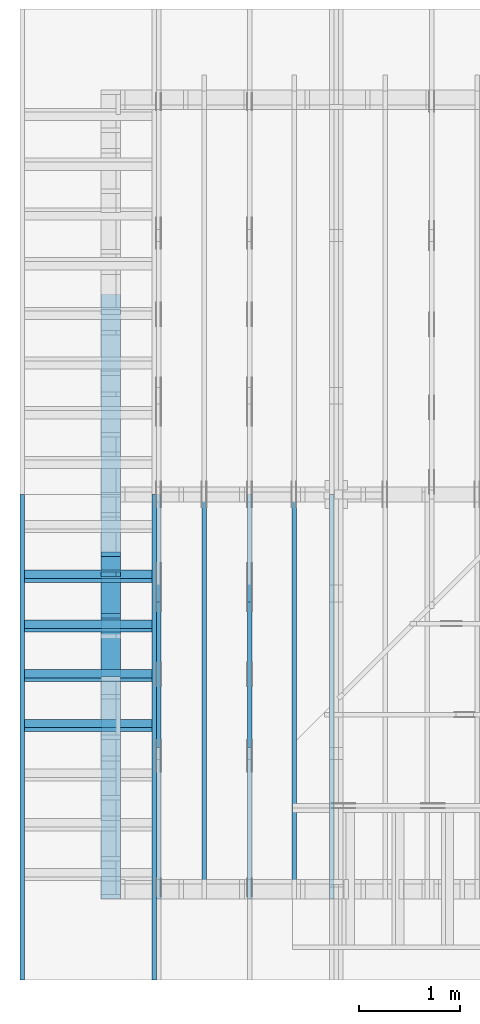
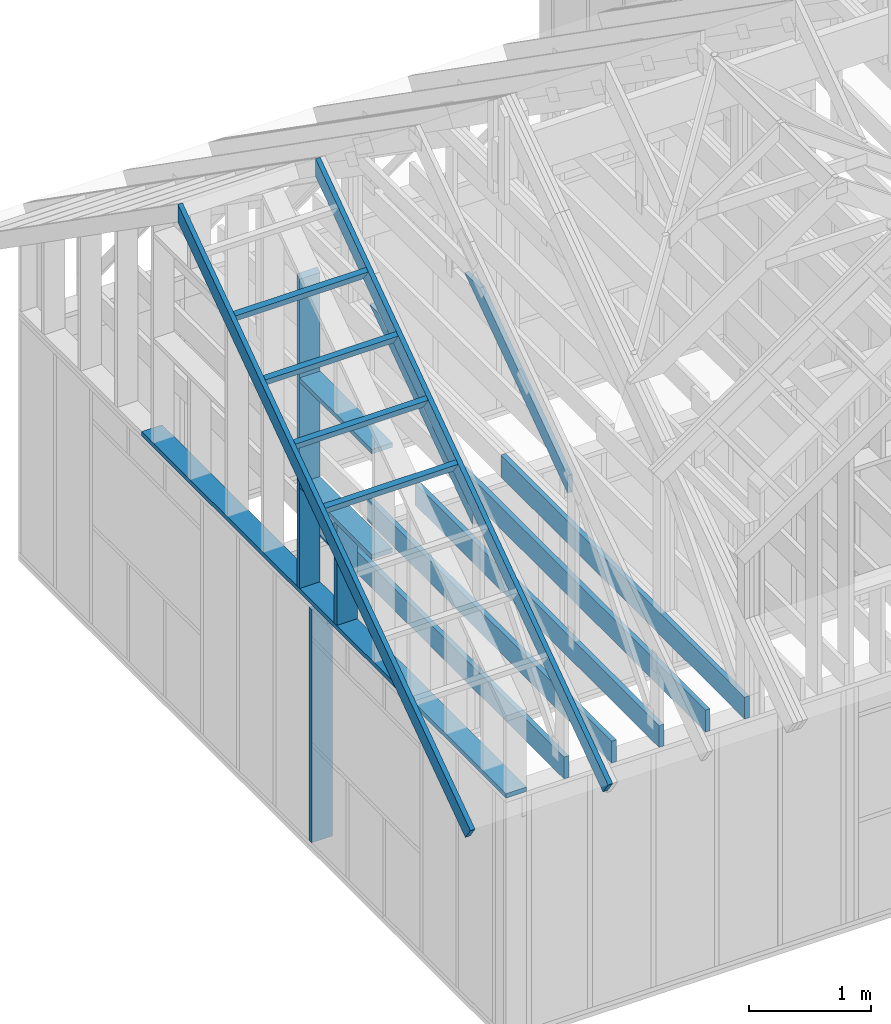
# One storey, part 5 of 70: 19 members, 8 elements without a shape of their own.
"""IFC2X3 building model written with IfcOpenShell, lengths in millimetres."""

from ifc_helpers import new_model, si_unit, frame, origin, origin_with_axes, origin_2d, place, context, project, spatial, faceted_brep, element, aggregate, save


model = new_model("IFC2X3")

# Units and contexts
model_context = context("Model", 3, precision=1e-05, world=origin())
plan_context = context("Plan", 2, precision=1e-05, world=origin_2d())
ifc_project = project(units=[si_unit("LENGTHUNIT", "METRE", prefix="MILLI"), si_unit("AREAUNIT", "SQUARE_METRE"), si_unit("VOLUMEUNIT", "CUBIC_METRE"), si_unit("SOLIDANGLEUNIT", "STERADIAN"), si_unit("PLANEANGLEUNIT", "RADIAN"), si_unit("MASSUNIT", "GRAM"), si_unit("TIMEUNIT", "SECOND"), si_unit("THERMODYNAMICTEMPERATUREUNIT", "DEGREE_CELSIUS"), si_unit("LUMINOUSINTENSITYUNIT", "LUMEN")], contexts=[model_context, plan_context])

# Site, building, storey
site_placement = place(None, origin_with_axes())
site = spatial("IfcSite", under=ifc_project, at=site_placement, CompositionType="ELEMENT")
building_placement = place(site_placement, origin_with_axes())
building = spatial("IfcBuilding", under=site, at=building_placement, Name="Layout 1", CompositionType="ELEMENT")
storey_placement = place(building_placement, origin_with_axes())
storey = spatial("IfcBuildingStorey", under=building, at=storey_placement, Name="Storey 1", CompositionType="ELEMENT", Elevation=0.0)

# Assembly, member
assembly_1_placement = place(storey_placement, frame((1969.9999999999982, 8000.000000000001, 1.1021457184401395e-14), z_axis=(-1.0, 1.836909530733566e-16, 6.123031769111886e-17), x_axis=(-1.836909530733566e-16, -1.0, 0.0)))
assembly_1 = element("IfcElementAssembly", 1, at=assembly_1_placement, inside=storey, Name="T11", AssemblyPlace="FACTORY", PredefinedType="TRUSS")
member_1_placement = place(assembly_1_placement, frame((7999.999999999999, 220.0, -90.0), z_axis=(0.0, 0.0, 1.0), x_axis=(-1.0, 1.2246063538223773e-16, 0.0)))
member_1 = element("IfcMember", 2, at=member_1_placement, Name="B3", context=model_context, shape_type="Brep", body=[
    faceted_brep([(3999.9999999999995, 220.00000000000054, 45.0), (0.0, 220.00000000000054, 45.0), (0.0, 0.0, 45.0), (3999.9999999999995, 0.0, 45.0), (0.0, 220.00000000000054, 0.0), (3999.9999999999995, 220.00000000000054, 4.898425415289508e-13), (3999.9999999999995, 0.0, 4.898425415289508e-13), (0.0, 0.0, 0.0), (0.0, 0.0, 0.0), (2.755364296100349e-15, -3.3742366240998092e-31, 45.0), (2.969670408019265e-14, 220.0, 45.0), (2.69413397840923e-14, 220.0, -1.6496267940043512e-30), (3999.9999999999995, -7.347638122934263e-13, 7.805495731188194e-29), (3999.9999999999995, -7.320084479973259e-13, 45.0), (5.061354936149714e-31, 2.755364296100349e-15, 45.0), (0.0, 0.0, 0.0), (3999.9999999999995, 220.00000000000054, 0.0), (3999.9999999999995, 220.00000000000054, 45.0), (3999.9999999999995, 5.400124791776761e-13, 45.0), (3999.9999999999995, 5.400124791776761e-13, 0.0), (0.0, 220.0, 0.0), (0.0, 220.0, 45.0), (3999.9999999999995, 220.00000000000065, 45.0), (3999.9999999999995, 220.00000000000065, 6.310887241768095e-30)], [[[0, 1, 2, 3]], [[4, 5, 6, 7]], [[8, 9, 10, 11]], [[12, 13, 14, 15]], [[16, 17, 18, 19]], [[20, 21, 22, 23]]]),
])
aggregate(assembly_1, [member_1])

# Assembly, members
assembly_2_placement = place(storey_placement, frame((304.9999999999989, 8000.000000000001, 1.3776821480501744e-15), z_axis=(-1.0, 1.836909530733566e-16, 6.123031769111886e-17), x_axis=(-1.836909530733566e-16, -1.0, 0.0)))
assembly_2 = element("IfcElementAssembly", 3, at=assembly_2_placement, inside=storey, Name="T2", AssemblyPlace="FACTORY", PredefinedType="TRUSS")
member_2_placement = place(assembly_2_placement, frame((7999.999999999999, 220.0, -45.0), z_axis=(0.0, 0.0, 1.0), x_axis=(-1.0, 1.2246063538223773e-16, 0.0)))
member_2 = element("IfcMember", 4, at=member_2_placement, Name="B3", context=model_context, shape_type="Brep", body=[
    faceted_brep([(3999.9999999999995, 220.00000000000048, 45.0), (0.0, 220.00000000000048, 45.0), (0.0, 0.0, 45.0), (3999.9999999999995, 0.0, 45.0), (0.0, 220.00000000000048, 0.0), (3999.9999999999995, 220.00000000000048, 4.898425415289508e-13), (3999.9999999999995, 0.0, 4.898425415289508e-13), (0.0, 0.0, 0.0), (0.0, 0.0, 0.0), (2.755364296100349e-15, -3.3742366240998092e-31, 45.0), (2.969670408019265e-14, 220.0, 45.0), (2.69413397840923e-14, 220.0, -1.6496267940043512e-30), (3999.9999999999995, -7.347638122934263e-13, 7.457441671638533e-29), (3999.9999999999995, -7.320084479973259e-13, 45.0), (5.061354936149714e-31, 2.755364296100349e-15, 45.0), (0.0, 0.0, 0.0), (3999.9999999999995, 220.00000000000048, 0.0), (3999.9999999999995, 220.00000000000048, 45.0), (3999.9999999999995, 4.831690603168681e-13, 45.0), (3999.9999999999995, 4.831690603168681e-13, 0.0), (0.0, 220.0, 0.0), (0.0, 220.0, 45.0), (3999.9999999999995, 220.00000000000065, 45.0), (3999.9999999999995, 220.00000000000065, 9.466330862652142e-30)], [[[0, 1, 2, 3]], [[4, 5, 6, 7]], [[8, 9, 10, 11]], [[12, 13, 14, 15]], [[16, 17, 18, 19]], [[20, 21, 22, 23]]]),
])
member_3_placement = place(assembly_2_placement, frame((6583.168583270555, 1754.024964553922, -45.0), z_axis=(0.0, 0.0, 1.0), x_axis=(-0.8191520442887741, 0.573576436351357, 0.0)))
member_3 = element("IfcMember", 5, at=member_3_placement, Name="SC5", context=model_context, shape_type="Brep", body=[
    faceted_brep([(2065.5522207412555, 145.00000000430646, 45.0), (0.0, 145.00000000430646, 45.0), (101.53009304075658, 0.0, 45.0), (1858.470759763978, 0.0, 45.0), (0.0, 145.00000000430646, 0.0), (2065.5522207412555, 145.00000000430646, 2.529488373671663e-13), (1858.470759763978, 0.0, 2.2758951008000685e-13), (101.53009304075658, 0.0, 1.2433439704188764e-14), (101.53009304075658, 7.105427357601002e-15, 0.0), (101.53009304075658, 7.105427357601002e-15, 45.0), (2.842170943040401e-14, 145.00000000026287, 45.0), (2.842170943040401e-14, 145.00000000026287, -1.5777218104420236e-30), (1858.470759763978, 4.5968566477253265e-09, -1.6558206515312064e-29), (1858.470759763978, 4.5968594030896226e-09, 45.0), (101.53009304075658, 1.7528947204142885e-14, 45.0), (101.53009304075658, 1.4773582908042536e-14, -9.04591174894424e-31), (2065.552220741256, 145.00000000430566, 5.048709793414476e-29), (2065.552220741256, 145.00000000430566, 45.0), (1858.4707597639788, 4.59590410173405e-09, 45.0), (1858.4707597639788, 4.59590410173405e-09, 5.048709793414476e-29), (0.0, 145.00000000026284, 0.0), (0.0, 145.00000000026284, 45.0), (2065.5522207412555, 145.00000000430657, 45.0), (2065.5522207412555, 145.0000000043066, 7.888609052210118e-30)], [[[0, 1, 2, 3]], [[4, 5, 6, 7]], [[8, 9, 10, 11]], [[12, 13, 14, 15]], [[16, 17, 18, 19]], [[20, 21, 22, 23]]]),
])
aggregate(assembly_2, [member_2, member_3])

assembly_3_placement = place(storey_placement, frame((1204.9999999999989, 8000.000000000001, 1.3776821480501744e-15), z_axis=(-1.0, 1.836909530733566e-16, 6.123031769111886e-17), x_axis=(-1.836909530733566e-16, -1.0, 0.0)))
assembly_3 = element("IfcElementAssembly", 6, at=assembly_3_placement, inside=storey, Name="T2", AssemblyPlace="FACTORY", PredefinedType="TRUSS")
member_4_placement = place(assembly_3_placement, frame((7999.999999999999, 220.0, -45.0), z_axis=(0.0, 0.0, 1.0), x_axis=(-1.0, 1.2246063538223773e-16, 0.0)))
member_4 = element("IfcMember", 7, at=member_4_placement, Name="B3", context=model_context, shape_type="Brep", body=[
    faceted_brep([(3999.9999999999995, 220.00000000000048, 45.0), (0.0, 220.00000000000048, 45.0), (0.0, 0.0, 45.0), (3999.9999999999995, 0.0, 45.0), (0.0, 220.00000000000048, 0.0), (3999.9999999999995, 220.00000000000048, 4.898425415289508e-13), (3999.9999999999995, 0.0, 4.898425415289508e-13), (0.0, 0.0, 0.0), (0.0, 0.0, 0.0), (2.755364296100349e-15, -3.3742366240998092e-31, 45.0), (2.969670408019265e-14, 220.0, 45.0), (2.69413397840923e-14, 220.0, -1.6496267940043512e-30), (3999.9999999999995, -7.347638122934263e-13, 7.457441671638533e-29), (3999.9999999999995, -7.320084479973259e-13, 45.0), (5.061354936149714e-31, 2.755364296100349e-15, 45.0), (0.0, 0.0, 0.0), (3999.9999999999995, 220.00000000000048, 0.0), (3999.9999999999995, 220.00000000000048, 45.0), (3999.9999999999995, 4.831690603168681e-13, 45.0), (3999.9999999999995, 4.831690603168681e-13, 0.0), (0.0, 220.0, 0.0), (0.0, 220.0, 45.0), (3999.9999999999995, 220.00000000000065, 45.0), (3999.9999999999995, 220.00000000000065, 9.466330862652142e-30)], [[[0, 1, 2, 3]], [[4, 5, 6, 7]], [[8, 9, 10, 11]], [[12, 13, 14, 15]], [[16, 17, 18, 19]], [[20, 21, 22, 23]]]),
])
member_5_placement = place(assembly_3_placement, frame((6583.168583270555, 1754.024964553922, -45.0), z_axis=(0.0, 0.0, 1.0), x_axis=(-0.8191520442887741, 0.573576436351357, 0.0)))
member_5 = element("IfcMember", 8, at=member_5_placement, Name="SC5", context=model_context, shape_type="Brep", body=[
    faceted_brep([(2065.5522207412555, 145.00000000430646, 45.0), (0.0, 145.00000000430646, 45.0), (101.53009304075658, 0.0, 45.0), (1858.470759763978, 0.0, 45.0), (0.0, 145.00000000430646, 0.0), (2065.5522207412555, 145.00000000430646, 2.529488373671663e-13), (1858.470759763978, 0.0, 2.2758951008000685e-13), (101.53009304075658, 0.0, 1.2433439704188764e-14), (101.53009304075658, 7.105427357601002e-15, 0.0), (101.53009304075658, 7.105427357601002e-15, 45.0), (2.842170943040401e-14, 145.00000000026287, 45.0), (2.842170943040401e-14, 145.00000000026287, -1.5777218104420236e-30), (1858.470759763978, 4.5968566477253265e-09, -1.6558206515312064e-29), (1858.470759763978, 4.5968594030896226e-09, 45.0), (101.53009304075658, 1.7528947204142885e-14, 45.0), (101.53009304075658, 1.4773582908042536e-14, -9.04591174894424e-31), (2065.552220741256, 145.00000000430566, 5.048709793414476e-29), (2065.552220741256, 145.00000000430566, 45.0), (1858.4707597639788, 4.59590410173405e-09, 45.0), (1858.4707597639788, 4.59590410173405e-09, 5.048709793414476e-29), (0.0, 145.00000000026284, 0.0), (0.0, 145.00000000026284, 45.0), (2065.5522207412555, 145.00000000430657, 45.0), (2065.5522207412555, 145.0000000043066, 7.888609052210118e-30)], [[[0, 1, 2, 3]], [[4, 5, 6, 7]], [[8, 9, 10, 11]], [[12, 13, 14, 15]], [[16, 17, 18, 19]], [[20, 21, 22, 23]]]),
])
aggregate(assembly_3, [member_4, member_5])

# Assembly, member
assembly_4_placement = place(storey_placement, frame((754.9999999999991, 8000.000000000001, 1.3776821480501744e-15), z_axis=(-1.0, 1.836909530733566e-16, 6.123031769111886e-17), x_axis=(-1.836909530733566e-16, -1.0, 0.0)))
assembly_4 = element("IfcElementAssembly", 9, at=assembly_4_placement, inside=storey, Name="MB1", AssemblyPlace="FACTORY", PredefinedType="TRUSS")
member_6_placement = place(assembly_4_placement, frame((8000.000000000001, 220.0, -45.0), z_axis=(0.0, 0.0, 1.0), x_axis=(-1.0, 1.2246063538223773e-16, 0.0)))
member_6 = element("IfcMember", 10, at=member_6_placement, Name="B3", context=model_context, shape_type="Brep", body=[
    faceted_brep([(4000.0000000000005, 220.0000000000005, 45.0), (0.0, 220.0000000000005, 45.0), (0.0, 0.0, 45.0), (4000.0000000000005, 0.0, 45.0), (0.0, 220.0000000000005, 0.0), (4000.0000000000005, 220.0000000000005, 4.89842541528951e-13), (4000.0000000000005, 0.0, 4.89842541528951e-13), (0.0, 0.0, 0.0), (0.0, 0.0, 0.0), (2.755364296100349e-15, -3.3742366240998092e-31, 45.0), (2.969670408019265e-14, 220.0, 45.0), (2.69413397840923e-14, 220.0, -1.6496267940043512e-30), (4000.0000000000005, -7.347638122934265e-13, 7.631468701413364e-29), (4000.0000000000005, -7.320084479973261e-13, 45.0), (5.061354936149714e-31, 2.755364296100349e-15, 45.0), (0.0, 0.0, 0.0), (4000.0000000000005, 220.0000000000005, 0.0), (4000.0000000000005, 220.0000000000005, 45.0), (4000.0000000000005, 5.115907697472721e-13, 45.0), (4000.0000000000005, 5.115907697472721e-13, 0.0), (0.0, 220.0, 0.0), (0.0, 220.0, 45.0), (4000.0000000000005, 220.00000000000065, 45.0), (4000.0000000000005, 220.00000000000065, 7.888609052210118e-30)], [[[0, 1, 2, 3]], [[4, 5, 6, 7]], [[8, 9, 10, 11]], [[12, 13, 14, 15]], [[16, 17, 18, 19]], [[20, 21, 22, 23]]]),
])
aggregate(assembly_4, [member_6])

assembly_5_placement = place(storey_placement, frame((1643.7499999999982, 8000.000000000001, 1.3776821480501744e-15), z_axis=(-1.0, 1.836909530733566e-16, 6.123031769111886e-17), x_axis=(-1.836909530733566e-16, -1.0, 0.0)))
assembly_5 = element("IfcElementAssembly", 11, at=assembly_5_placement, inside=storey, Name="MB1", AssemblyPlace="FACTORY", PredefinedType="TRUSS")
member_7_placement = place(assembly_5_placement, frame((8000.000000000001, 220.0, -45.0), z_axis=(0.0, 0.0, 1.0), x_axis=(-1.0, 1.2246063538223773e-16, 0.0)))
member_7 = element("IfcMember", 12, at=member_7_placement, Name="B3", context=model_context, shape_type="Brep", body=[
    faceted_brep([(4000.0000000000005, 220.0000000000005, 45.0), (0.0, 220.0000000000005, 45.0), (0.0, 0.0, 45.0), (4000.0000000000005, 0.0, 45.0), (0.0, 220.0000000000005, 0.0), (4000.0000000000005, 220.0000000000005, 4.89842541528951e-13), (4000.0000000000005, 0.0, 4.89842541528951e-13), (0.0, 0.0, 0.0), (0.0, 0.0, 0.0), (2.755364296100349e-15, -3.3742366240998092e-31, 45.0), (2.969670408019265e-14, 220.0, 45.0), (2.69413397840923e-14, 220.0, -1.6496267940043512e-30), (4000.0000000000005, -7.347638122934265e-13, 7.631468701413364e-29), (4000.0000000000005, -7.320084479973261e-13, 45.0), (5.061354936149714e-31, 2.755364296100349e-15, 45.0), (0.0, 0.0, 0.0), (4000.0000000000005, 220.0000000000005, 0.0), (4000.0000000000005, 220.0000000000005, 45.0), (4000.0000000000005, 5.115907697472721e-13, 45.0), (4000.0000000000005, 5.115907697472721e-13, 0.0), (0.0, 220.0, 0.0), (0.0, 220.0, 45.0), (4000.0000000000005, 220.00000000000065, 45.0), (4000.0000000000005, 220.00000000000065, 7.888609052210118e-30)], [[[0, 1, 2, 3]], [[4, 5, 6, 7]], [[8, 9, 10, 11]], [[12, 13, 14, 15]], [[16, 17, 18, 19]], [[20, 21, 22, 23]]]),
])
aggregate(assembly_5, [member_7])

assembly_6_placement = place(storey_placement, frame((-243.55339059327574, 8000.000000000001, -2470.0), z_axis=(-1.0, 1.836909530733566e-16, 6.123031769111886e-17), x_axis=(-1.836909530733566e-16, -1.0, 0.0)))
assembly_6 = element("IfcElementAssembly", 13, at=assembly_6_placement, inside=storey, Name="VE3", AssemblyPlace="FACTORY", PredefinedType="NOTDEFINED")
member_8_placement = place(assembly_6_placement, frame((4767.5000000036525, 2425.0, -195.00000000000003), z_axis=(0.0, 0.0, 1.0), x_axis=(-1.836909530733566e-16, -1.0, 0.0)))
member_8 = element("IfcMember", 14, at=member_8_placement, Name="S11", context=model_context, shape_type="Brep", body=[
    faceted_brep([(0.0, 45.0, 45.00000000000003), (195.00000000186265, 45.0, 45.00000000000005), (195.00000000186265, 0.0, 45.00000000000005), (0.0, 0.0, 45.00000000000003), (195.00000000186265, -2.1311460639909362e-46, 2.842170943040401e-14), (195.00000000186265, -3.3742366240998114e-31, 45.00000000000003), (195.00000000186265, 45.0, 45.00000000000003), (195.00000000186265, 45.0, 2.842170943040401e-14), (2.7553642961003504e-15, -3.3742366240998114e-31, 45.00000000000003), (1.193991194976818e-14, -1.4621692037765842e-30, 195.00000000000003), (1.7450640541968876e-14, 45.0, 195.00000000000003), (8.266092888301048e-15, 45.0, 45.00000000000003), (2335.0, -4.2891837542628763e-13, 2.842170943040403e-14), (2335.0, -4.1697846347651946e-13, 195.00000000000003), (2.1932538056648764e-30, 1.193991194976818e-14, 195.00000000000003), (5.061354936149717e-31, 2.7553642961003504e-15, 45.00000000000003), (195.00000000186265, -3.306437155354634e-14, 45.00000000000003), (195.00000000186265, -3.5819735849646686e-14, 2.842170943040401e-14), (-1.6871183120499057e-31, 45.0, 45.00000000000003), (-7.310846018882921e-31, 44.999999999999986, 195.00000000000003), (2335.0, 44.999999999999844, 195.00000000000003), (2335.0, 44.99999999999986, 2.8421709430403998e-14), (195.00000000186265, 44.999999999999986, 2.842170943040401e-14), (195.00000000186265, 44.999999999999986, 45.00000000000003), (2335.0, 45.0, 0.0), (2335.0, 45.0, 195.00000000000003), (2335.0, 0.0, 195.00000000000003), (2335.0, 0.0, 0.0), (2335.0, 45.0, 195.00000000000003), (0.0, 45.0, 195.00000000000003), (0.0, 0.0, 195.00000000000003), (2335.0, 0.0, 195.00000000000003), (195.00000000186265, 45.0, 5.2301533330168465e-14), (2335.0, 45.0, 3.143672930479291e-13), (2335.0, 0.0, 3.143672930479291e-13), (195.00000000186265, 0.0, 5.2301533330168465e-14)], [[[0, 1, 2, 3]], [[4, 5, 6, 7]], [[8, 9, 10, 11]], [[12, 13, 14, 15, 16, 17]], [[18, 19, 20, 21, 22, 23]], [[24, 25, 26, 27]], [[28, 29, 30, 31]], [[32, 33, 34, 35]]]),
])
aggregate(assembly_6, [member_8])

# Assembly, members
assembly_7_placement = place(storey_placement, frame((-48.55339059327645, 2.2546681725408788e-11, 1.1939911949768178e-14), z_axis=(1.0, 1.156240088482502e-13, 6.123031769111886e-17), x_axis=(-1.156240088482502e-13, 1.0, 0.0)))
assembly_7 = element("IfcElementAssembly", 15, at=assembly_7_placement, inside=storey, Name="VEg1", AssemblyPlace="FACTORY", PredefinedType="NOTDEFINED")
member_9_placement = place(assembly_7_placement, frame((5980.000000000011, 45.0, -195.0), z_axis=(0.0, 0.0, 1.0), x_axis=(-1.0, 1.2246063538223773e-16, 0.0)))
member_9 = element("IfcMember", 16, at=member_9_placement, Name="P1", context=model_context, shape_type="Brep", body=[
    faceted_brep([(5980.0, 45.00000000000073, 195.0), (0.0, 45.00000000000073, 195.0), (0.0, 0.0, 195.0), (5980.0, 0.0, 195.0), (0.0, 45.00000000000073, 0.0), (5980.0, 45.00000000000073, 7.323145995857816e-13), (5980.0, 0.0, 7.323145995857816e-13), (0.0, 0.0, 0.0), (0.0, 0.0, 0.0), (1.1939911949768178e-14, -1.462169203776584e-30, 195.0), (1.7450640541968876e-14, 45.0, 195.0), (5.510728592200698e-15, 45.0, -3.3742366240998092e-31), (5980.0, -1.0984718993786724e-12, 1.1207174354074175e-28), (5980.0, -1.0865319874289042e-12, 195.0), (2.193253805664876e-30, 1.1939911949768178e-14, 195.0), (0.0, 0.0, 0.0), (5980.0, 45.00000000000073, 0.0), (5980.0, 45.00000000000073, 195.0), (5980.0, 7.318590178329032e-13, 195.0), (5980.0, 7.318590178329032e-13, 0.0), (0.0, 45.0, 0.0), (1.5777218104420236e-30, 44.999999999999986, 195.0), (5980.0, 45.00000000000095, 195.0), (5980.0, 45.00000000000096, 1.3805065841367707e-29)], [[[0, 1, 2, 3]], [[4, 5, 6, 7]], [[8, 9, 10, 11]], [[12, 13, 14, 15]], [[16, 17, 18, 19]], [[20, 21, 22, 23]]]),
])
member_10_placement = place(assembly_7_placement, frame((3387.5000000011937, 3171.5152030411555, -195.0), z_axis=(0.0, 0.0, 1.0), x_axis=(-1.836909530733566e-16, -1.0, 0.0)))
member_10 = element("IfcMember", 17, at=member_10_placement, Name="S6", context=model_context, shape_type="Brep", body=[
    faceted_brep([(3126.5152030411555, 45.000000000029104, 195.0), (0.0, 45.000000000029104, 195.0), (31.509339219453977, 1.4097167877480388e-11, 195.0), (3126.5152030411555, 1.4097167877480388e-11, 195.0), (0.0, 45.000000000029104, 0.0), (3126.5152030411555, 45.000000000029104, 3.828750382966459e-13), (3126.5152030411555, 1.4097167877480388e-11, 3.828750382966459e-13), (31.509339219453977, 1.4097167877480388e-11, 3.8586537012887966e-15), (31.509339219453974, 1.4090062450122787e-11, 3.944304526105059e-31), (31.509339219453985, 1.4097167877480388e-11, 195.0), (2.1316282072803006e-14, 45.00000000002866, 195.0), (1.0658141036401503e-14, 45.00000000002865, -7.888609052210118e-31), (3126.5152030411555, -2.1814224467073119e-13, 1.33569189430426e-29), (3126.5152030411555, -2.06202332720963e-13, 195.0), (31.509339219453977, 1.4106909329630971e-11, 195.0), (31.509339219453977, 1.4094969417681203e-11, 1.3461239193521642e-31), (3126.5152030411555, 45.000000000029104, 0.0), (3126.5152030411555, 45.000000000029104, 195.0), (3126.5152030411555, 0.0, 195.0), (3126.5152030411555, 0.0, 0.0), (0.0, 45.00000000002865, 0.0), (1.5777218104420236e-30, 45.000000000028635, 195.0), (3126.5152030411555, 45.00000000002914, 195.0), (3126.5152030411555, 45.000000000029154, 2.7610131682735413e-30)], [[[0, 1, 2, 3]], [[4, 5, 6, 7]], [[8, 9, 10, 11]], [[12, 13, 14, 15]], [[16, 17, 18, 19]], [[20, 21, 22, 23]]]),
])
member_11_placement = place(assembly_7_placement, frame((3387.4999999993743, 2154.9999999987776, -195.0), z_axis=(0.0, 0.0, 1.0), x_axis=(-1.0, 1.2246063538223773e-16, 0.0)))
member_11 = element("IfcMember", 18, at=member_11_placement, Name="S24", context=model_context, shape_type="Brep", body=[
    faceted_brep([(1184.9999999981374, 45.0, 195.0), (0.0, 45.0, 195.0), (0.0, 0.0, 195.0), (1184.9999999981374, 0.0, 195.0), (0.0, 45.0, 0.0), (1184.9999999981374, 45.0, 1.451158529277236e-13), (1184.9999999981374, 0.0, 1.451158529277236e-13), (0.0, 0.0, 0.0), (0.0, 0.0, 0.0), (1.1939911949768178e-14, -1.462169203776584e-30, 195.0), (1.7450640541968876e-14, 45.0, 195.0), (5.510728592200698e-15, 45.0, -3.3742366240998092e-31), (1184.9999999981374, 1.4517206203410331e-11, 2.1252446248367873e-30), (1184.9999999981374, 1.45291461153601e-11, 195.0), (-1.462735559709875e-28, 1.1939911949768178e-14, 195.0), (0.0, 0.0, 0.0), (1184.9999999981374, 45.0, 0.0), (1184.9999999981374, 45.0, 195.0), (1184.9999999981374, 1.4551915228366852e-11, 195.0), (1184.9999999981374, 1.4551915228366852e-11, 0.0), (0.0, 45.0, 0.0), (-7.31084601888292e-31, 44.999999999999986, 195.0), (1184.9999999981374, 44.999999999999915, 195.0), (1184.9999999981374, 44.99999999999993, -4.338734978715565e-30)], [[[0, 1, 2, 3]], [[4, 5, 6, 7]], [[8, 9, 10, 11]], [[12, 13, 14, 15]], [[16, 17, 18, 19]], [[20, 21, 22, 23]]]),
])
member_12_placement = place(assembly_7_placement, frame((2202.500000001237, 1054.9999999999854, -195.0), z_axis=(0.0, 0.0, 1.0), x_axis=(1.0, 0.0, 0.0)))
member_12 = element("IfcMember", 19, at=member_12_placement, Name="S24", context=model_context, shape_type="Brep", body=[
    faceted_brep([(1184.9999999981374, 45.0, 195.0), (0.0, 45.0, 195.0), (0.0, 2.9103830456733704e-11, 195.0), (1184.9999999981374, 2.9103830456733704e-11, 195.0), (0.0, 45.0, 0.0), (1184.9999999981374, 45.0, 1.451158529277236e-13), (1184.9999999981374, 2.9103830456733704e-11, 1.451158529277236e-13), (0.0, 2.9103830456733704e-11, 0.0), (3.564073569788531e-27, 2.9103830456733704e-11, -2.1822935695267187e-43), (1.1939911949771742e-14, 2.9103830456733704e-11, 195.0), (1.745064054197066e-14, 45.00000000001455, 195.0), (5.51072859220248e-15, 45.00000000001455, -3.3742366241009005e-31), (1184.9999999981374, -5.836032882617145e-13, 3.5734214745846387e-29), (1184.9999999981374, -5.716633763119464e-13, 195.0), (2.9912687335896964e-28, 2.911577036868347e-11, 195.0), (0.0, 2.9103830456733704e-11, 0.0), (1184.9999999981374, 45.0, 0.0), (1184.9999999981374, 45.0, 195.0), (1184.9999999981374, 0.0, 195.0), (1184.9999999981374, 0.0, 0.0), (0.0, 45.00000000001455, 0.0), (-1.0097419586828951e-28, 45.00000000001454, 195.0), (1184.9999999981374, 44.99999999999999, 195.0), (1184.9999999981374, 45.00000000000001, 3.944304526105059e-31)], [[[0, 1, 2, 3]], [[4, 5, 6, 7]], [[8, 9, 10, 11]], [[12, 13, 14, 15]], [[16, 17, 18, 19]], [[20, 21, 22, 23]]]),
])
member_13_placement = place(assembly_7_placement, frame((2822.4999999994034, 45.0, -195.0), z_axis=(0.0, 0.0, 1.0), x_axis=(6.123031769111886e-17, 1.0, 0.0)))
member_13 = element("IfcMember", 20, at=member_13_placement, Name="S31", context=model_context, shape_type="Brep", body=[
    faceted_brep([(1010.0, 45.00000000001455, 195.0), (0.0, 45.00000000001455, 195.0), (0.0, 1.4551915228366852e-11, 195.0), (1010.0, 1.4551915228366852e-11, 195.0), (0.0, 45.00000000001455, 0.0), (1010.0, 45.00000000001455, 1.236852417360601e-13), (1010.0, 1.4551915228366852e-11, 1.236852417360601e-13), (0.0, 1.4551915228366852e-11, 0.0), (1.7820367848942657e-27, 1.4551915228366852e-11, -1.0911467847633593e-43), (1.1939911949769961e-14, 1.4551915228366852e-11, 195.0), (1.745064054197066e-14, 45.00000000001455, 195.0), (5.51072859220248e-15, 45.00000000001455, -3.3742366241009005e-31), (1010.0, 1.3424103408737897e-14, -8.219621164354531e-31), (1010.0, 2.5364015358506076e-14, 195.0), (1.7186960783612474e-28, 1.456385514031662e-11, 195.0), (0.0, 1.4551915228366852e-11, 0.0), (1010.0, 45.00000000001455, 0.0), (1010.0, 45.00000000001455, 195.0), (1010.0, 0.0, 195.0), (1010.0, 0.0, 0.0), (-1.2154326714572542e-63, 45.00000000001455, 0.0), (-7.31084601888292e-31, 45.00000000001454, 195.0), (1010.0, 45.00000000001448, 195.0), (1010.0, 45.00000000001449, -3.944304526105059e-30)], [[[0, 1, 2, 3]], [[4, 5, 6, 7]], [[8, 9, 10, 11]], [[12, 13, 14, 15]], [[16, 17, 18, 19]], [[20, 21, 22, 23]]]),
])
aggregate(assembly_7, [member_9, member_10, member_11, member_12, member_13])

assembly_8_placement = place(storey_placement, frame((304.99999999999886, -800.0, 439.83396943223215), z_axis=(-2.4046889635939937e-17, -0.573576436351046, 0.8191520442889918), x_axis=(1.5036672491230068e-17, 0.8191520442889918, 0.573576436351046)))
assembly_8 = element("IfcElementAssembly", 21, at=assembly_8_placement, inside=storey, Name="gs1", AssemblyPlace="FACTORY", PredefinedType="TRUSS")
member_14_placement = place(assembly_8_placement, frame((-4.013226075628794e-10, 1303.5533905941993, -145.0), z_axis=(0.0, 0.0, 1.0), x_axis=(1.0, 0.0, 0.0)))
member_14 = element("IfcMember", 22, at=member_14_placement, Name="T2", context=model_context, shape_type="Brep", body=[
    faceted_brep([(5758.187933013301, 45.0, 5.5933924159035087e-11), (5859.718026055391, 45.0, 145.0), (5859.718026055391, 0.0, 145.0), (5758.187933013301, 0.0, 5.5933924159035087e-11), (2.3544408101802167e-13, 45.0, 0.0), (2.3544408101802167e-13, 44.99999999999999, 145.0), (5859.718026055391, 44.99999999999963, 145.0), (5758.18793301338, 44.999999999999645, -2.1693674893577825e-29), (2.3544408101802167e-13, 45.0, 2.883263175845399e-29), (5758.18793301338, 45.0, 7.051513529271526e-13), (5758.18793301338, 0.0, 7.051513529271526e-13), (1.2968369905839017e-11, 0.0, 1.5881148185409364e-27), (1.2993463288158048e-11, 0.0, 2.8421709430404004e-14), (1.3259913425936296e-11, 7.688033059457876e-26, 145.0), (2.758147664141655e-13, 45.0, 145.0), (9.364628635916929e-15, 45.0, -1.720832131229218e-29), (5859.718026055391, -1.0674987928820304e-12, 145.0), (1.2968369905839017e-11, 8.878396065209853e-15, 145.0), (1.2968369905839017e-11, -2.382172227811405e-27, 1.4586116230385269e-43), (5758.18793301338, -1.0577270293907289e-12, 6.476496204007775e-29), (5859.718026055391, 45.0, 145.0), (2.3544408101802167e-13, 45.0, 145.0), (1.2968369905839017e-11, 0.0, 145.0), (5859.718026055391, 0.0, 145.0)], [[[0, 1, 2, 3]], [[4, 5, 6, 7]], [[8, 9, 10, 11]], [[12, 13, 14, 15]], [[16, 17, 18, 19]], [[20, 21, 22, 23]]]),
])
member_15_placement = place(assembly_8_placement, frame((5859.71802605499, 45.0, -145.00000000007535), z_axis=(0.0, 0.0, 1.0), x_axis=(-1.0, 1.2246063538223773e-16, 0.0)))
member_15 = element("IfcMember", 23, at=member_15_placement, Name="T2", context=model_context, shape_type="Brep", body=[
    faceted_brep([(101.53009304190417, 1.3402191241451355e-12, -1.4921397450962104e-13), (9.094947017729282e-13, 1.0097419586828951e-28, 145.0000000000762), (9.094947017729282e-13, 44.99999999999999, 145.00000000007535), (101.53009304190347, 45.000000000001336, -7.105427357601002e-15), (5859.718026055004, -1.0763771889471667e-12, 7.534595170000102e-11), (5859.718026055004, -1.0674987928819545e-12, 145.00000000007535), (1.630881034982422e-30, 8.878396065216848e-15, 145.00000000007535), (101.53009304201169, -1.8650159556509083e-14, 7.534595170000102e-11), (101.53009304201078, 45.000000000000014, 7.535838513970537e-11), (5859.71802605499, 45.000000000000014, 7.606353649263247e-11), (5859.718026055004, 7.176481631177012e-13, 7.606353649263247e-11), (101.53009304201169, 7.176481631177012e-13, 7.535838513970537e-11), (9.094947017729282e-13, 45.00000000000001, 145.00000000007535), (5859.71802605499, 44.999999999999645, 145.00000000007535), (5859.71802605499, 44.99999999999966, 7.534595170000102e-11), (101.53009304201078, 45.00000000000001, 7.534595170000102e-11), (5859.718026055004, 45.00000000000072, 7.537437340943143e-11), (5859.718026055004, 45.00000000000072, 145.00000000007535), (5859.718026055004, 7.247535904753022e-13, 145.00000000007535), (5859.718026055004, 7.247535904753022e-13, 7.534595170000102e-11), (5859.71802605499, 45.00000000000072, 145.00000000007535), (9.094947017729282e-13, 45.00000000000072, 145.00000000007535), (0.0, 0.0, 145.00000000007535), (5859.718026055004, 0.0, 145.00000000007535)], [[[0, 1, 2, 3]], [[4, 5, 6, 7]], [[8, 9, 10, 11]], [[12, 13, 14, 15]], [[16, 17, 18, 19]], [[20, 21, 22, 23]]]),
])
member_16_placement = place(assembly_8_placement, frame((3044.9999999989814, 45.0, -145.0), z_axis=(0.0, 0.0, 1.0), x_axis=(6.123031769111886e-17, 1.0, 0.0)))
member_16 = element("IfcMember", 24, at=member_16_placement, Name="W4", context=model_context, shape_type="Brep", body=[
    faceted_brep([(1258.5533905932764, 45.00000000001455, 145.0), (0.0, 45.00000000001455, 145.0), (0.0, 0.0, 145.0), (1258.5533905932764, 0.0, 145.0), (0.0, 45.00000000001455, 0.0), (1258.5533905932764, 45.00000000001455, 1.5412324787452224e-13), (1258.5533905932764, 0.0, 1.5412324787452224e-13), (0.0, 0.0, 0.0), (0.0, 0.0, 0.0), (8.878396065212235e-15, -1.0872540233210496e-30, 145.0), (1.4389124657412933e-14, 45.0, 145.0), (5.510728592200698e-15, 45.0, -3.3742366240998092e-31), (1258.5533905932764, -2.3118487181178335e-13, 1.4155523146416086e-29), (1258.5533905932764, -2.2230647574657112e-13, 145.0), (1.6308810349815745e-30, 8.878396065212235e-15, 145.0), (0.0, 0.0, 0.0), (1258.5533905932764, 45.00000000001455, 0.0), (1258.5533905932764, 45.00000000001455, 145.0), (1258.5533905932764, 0.0, 145.0), (1258.5533905932764, 0.0, 0.0), (0.0, 45.0, 0.0), (1.0097419586828951e-28, 44.99999999999999, 145.0), (1258.5533905932764, 45.00000000001472, 145.0), (1258.5533905932764, 45.00000000001474, 1.1044052673094165e-29)], [[[0, 1, 2, 3]], [[4, 5, 6, 7]], [[8, 9, 10, 11]], [[12, 13, 14, 15]], [[16, 17, 18, 19]], [[20, 21, 22, 23]]]),
])
member_17_placement = place(assembly_8_placement, frame((3644.9999999989814, 45.0, -145.0), z_axis=(0.0, 0.0, 1.0), x_axis=(6.123031769111886e-17, 1.0, 0.0)))
member_17 = element("IfcMember", 25, at=member_17_placement, Name="W4", context=model_context, shape_type="Brep", body=[
    faceted_brep([(1258.5533905932764, 45.0, 145.0), (0.0, 45.0, 145.0), (0.0, 0.0, 145.0), (1258.5533905932764, 0.0, 145.0), (0.0, 45.0, 0.0), (1258.5533905932764, 45.0, 1.5412324787452224e-13), (1258.5533905932764, 0.0, 1.5412324787452224e-13), (0.0, 0.0, 0.0), (0.0, 0.0, 0.0), (8.878396065212235e-15, -1.0872540233210496e-30, 145.0), (1.4389124657412933e-14, 45.0, 145.0), (5.510728592200698e-15, 45.0, -3.3742366240998092e-31), (1258.5533905932764, -2.3118487181178335e-13, 1.4155523146416086e-29), (1258.5533905932764, -2.2230647574657112e-13, 145.0), (1.6308810349815745e-30, 8.878396065212235e-15, 145.0), (0.0, 0.0, 0.0), (1258.5533905932764, 45.0, 0.0), (1258.5533905932764, 45.0, 145.0), (1258.5533905932764, 0.0, 145.0), (1258.5533905932764, 0.0, 0.0), (0.0, 45.0, 0.0), (-5.436270116605248e-31, 44.99999999999999, 145.0), (1258.5533905932764, 44.999999999999915, 145.0), (1258.5533905932764, 44.99999999999992, -4.733165431326071e-30)], [[[0, 1, 2, 3]], [[4, 5, 6, 7]], [[8, 9, 10, 11]], [[12, 13, 14, 15]], [[16, 17, 18, 19]], [[20, 21, 22, 23]]]),
])
member_18_placement = place(assembly_8_placement, frame((4244.999999998981, 44.99999999999999, -145.0), z_axis=(0.0, 0.0, 1.0), x_axis=(6.123031769111886e-17, 1.0, 0.0)))
member_18 = element("IfcMember", 26, at=member_18_placement, Name="W4", context=model_context, shape_type="Brep", body=[
    faceted_brep([(1258.5533905932764, 45.0, 145.0), (0.0, 45.0, 145.0), (7.105427357601002e-15, 0.0, 145.0), (1258.5533905932764, 0.0, 145.0), (0.0, 45.0, 0.0), (1258.5533905932764, 45.0, 1.5412324787452224e-13), (1258.5533905932764, 0.0, 1.5412324787452224e-13), (7.105427357601002e-15, 0.0, 8.701351488741532e-31), (7.105427357601002e-15, 0.0, 0.0), (1.5983823422813237e-14, -1.0872540233210496e-30, 145.0), (2.1494552015013935e-14, 45.0, 145.0), (1.26161559498017e-14, 45.0, -7.724912368470575e-31), (1258.5533905932764, -2.3118487181178335e-13, 1.4155523146416086e-29), (1258.5533905932764, -2.2230647574657112e-13, 145.0), (7.105427357601003e-15, 8.878396065212234e-15, 145.0), (7.105427357601002e-15, -1.3052027233112297e-30, 7.991797739966011e-47), (1258.5533905932764, 45.0, 0.0), (1258.5533905932764, 45.0, 145.0), (1258.5533905932764, 0.0, 145.0), (1258.5533905932764, 0.0, 0.0), (0.0, 45.0, 0.0), (-5.436270116605248e-31, 44.99999999999999, 145.0), (1258.5533905932764, 44.999999999999915, 145.0), (1258.5533905932764, 44.99999999999992, -4.733165431326071e-30)], [[[0, 1, 2, 3]], [[4, 5, 6, 7]], [[8, 9, 10, 11]], [[12, 13, 14, 15]], [[16, 17, 18, 19]], [[20, 21, 22, 23]]]),
])
member_19_placement = place(assembly_8_placement, frame((4844.999999998981, 44.99999999999999, -145.0), z_axis=(0.0, 0.0, 1.0), x_axis=(6.123031769111886e-17, 1.0, 0.0)))
member_19 = element("IfcMember", 27, at=member_19_placement, Name="W4", context=model_context, shape_type="Brep", body=[
    faceted_brep([(1258.5533905932764, 44.99999999998545, 145.0), (0.0, 44.99999999998545, 145.0), (7.105427357601002e-15, 0.0, 145.0), (1258.5533905932764, 0.0, 145.0), (0.0, 44.99999999998545, 0.0), (1258.5533905932764, 44.99999999998545, 1.5412324787452224e-13), (1258.5533905932764, 0.0, 1.5412324787452224e-13), (7.105427357601002e-15, 0.0, 8.701351488741532e-31), (7.105427357601002e-15, 0.0, 0.0), (1.5983823422813237e-14, -1.0872540233210496e-30, 145.0), (2.1494552015013935e-14, 45.0, 145.0), (1.26161559498017e-14, 45.0, -7.724912368470575e-31), (1258.5533905932764, -2.3118487181178335e-13, 1.4155523146416086e-29), (1258.5533905932764, -2.2230647574657112e-13, 145.0), (7.105427357601003e-15, 8.878396065212234e-15, 145.0), (7.105427357601002e-15, -1.3052027233112297e-30, 7.991797739966011e-47), (1258.5533905932764, 44.99999999998545, 0.0), (1258.5533905932764, 44.99999999998545, 145.0), (1258.5533905932764, 0.0, 145.0), (1258.5533905932764, 0.0, 0.0), (0.0, 45.0, 0.0), (-1.0097419586828951e-28, 44.99999999999999, 145.0), (1258.5533905932764, 44.999999999985384, 145.0), (1258.5533905932764, 44.99999999998539, -3.549874073494553e-30)], [[[0, 1, 2, 3]], [[4, 5, 6, 7]], [[8, 9, 10, 11]], [[12, 13, 14, 15]], [[16, 17, 18, 19]], [[20, 21, 22, 23]]]),
])
aggregate(assembly_8, [member_14, member_15, member_16, member_17, member_18, member_19])

save(model, "model.ifc")
